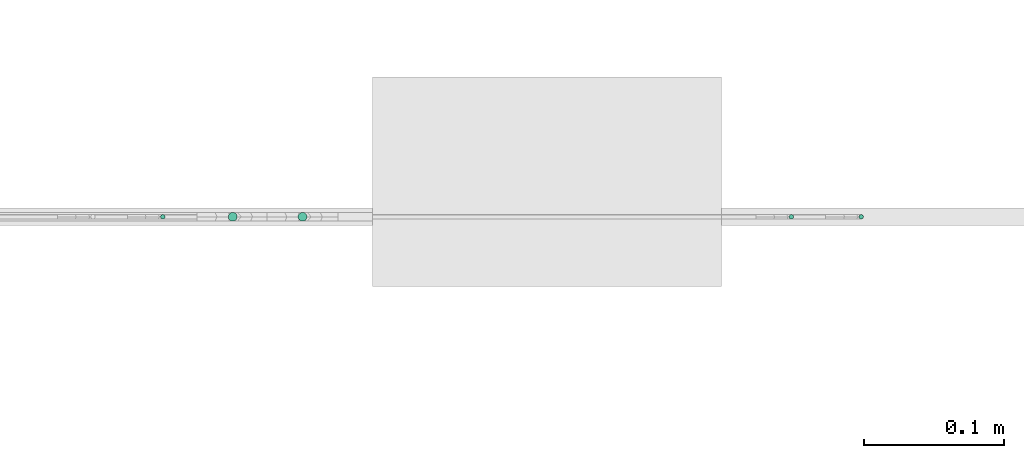
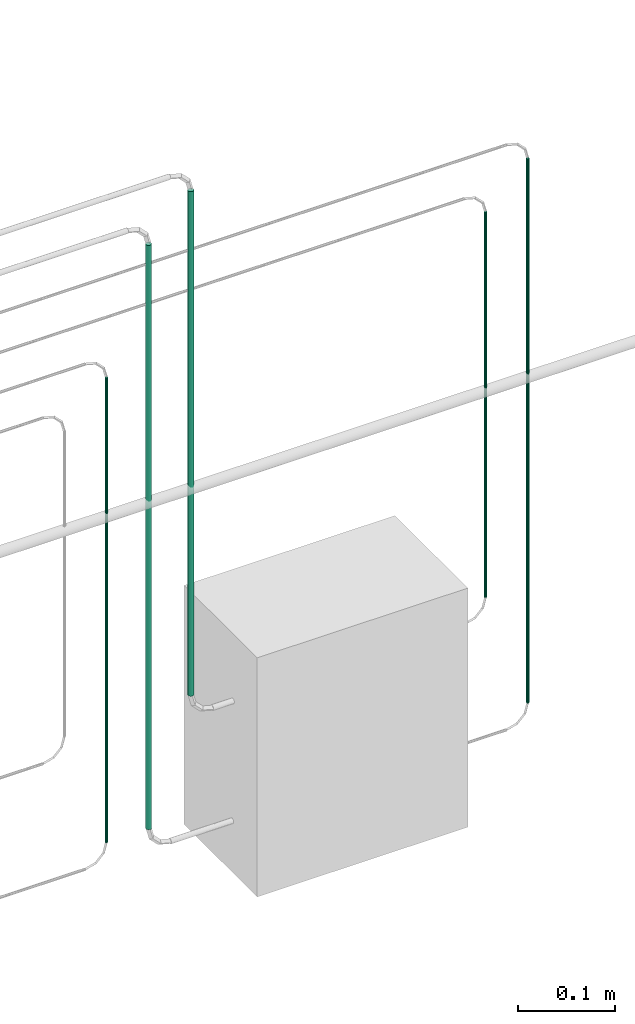
# One storey, part 24 of 45: 5 flow segments.
"""IFC2X3 building model written with IfcOpenShell, lengths in millimetres."""

from ifc_helpers import new_model, entity, si_unit, converted_unit, derived_unit, direction, frame, origin, origin_2d_with_axis, place, context, subcontext, project, spatial, circle, extrude, type_object, element, save


model = new_model("IFC2X3")

# Units and contexts
model_context = context("Model", 3, precision=0.01, world=origin(), true_north=direction((6.12303176911189e-17, 1.0)))
body_context = subcontext(model_context, "Body", "Model", "MODEL_VIEW")
ifc_project = project(units=[si_unit("LENGTHUNIT", "METRE", prefix="MILLI"), si_unit("AREAUNIT", "SQUARE_METRE"), si_unit("VOLUMEUNIT", "CUBIC_METRE"), converted_unit("PLANEANGLEUNIT", "DEGREE", entity("IfcRatioMeasure", 0.0174532925199433), si_unit("PLANEANGLEUNIT", "RADIAN"), dimensions=[0, 0, 0, 0, 0, 0, 0]), si_unit("MASSUNIT", "GRAM", prefix="KILO"), derived_unit("MASSDENSITYUNIT", [(si_unit("MASSUNIT", "GRAM", prefix="KILO"), 1), (si_unit("LENGTHUNIT", "METRE"), -3)]), derived_unit("MOMENTOFINERTIAUNIT", [(si_unit("LENGTHUNIT", "METRE"), 4)]), si_unit("TIMEUNIT", "SECOND"), si_unit("FREQUENCYUNIT", "HERTZ"), si_unit("THERMODYNAMICTEMPERATUREUNIT", "DEGREE_CELSIUS"), derived_unit("THERMALTRANSMITTANCEUNIT", [(si_unit("MASSUNIT", "GRAM", prefix="KILO"), 1), (si_unit("THERMODYNAMICTEMPERATUREUNIT", "KELVIN"), -1), (si_unit("TIMEUNIT", "SECOND"), -3)]), derived_unit("VOLUMETRICFLOWRATEUNIT", [(si_unit("LENGTHUNIT", "METRE"), 3), (si_unit("TIMEUNIT", "SECOND"), -1)]), derived_unit("MASSFLOWRATEUNIT", [(si_unit("MASSUNIT", "GRAM", prefix="KILO"), 1), (si_unit("TIMEUNIT", "SECOND"), -1)]), derived_unit("ROTATIONALFREQUENCYUNIT", [(si_unit("TIMEUNIT", "SECOND"), -1)]), si_unit("ELECTRICCURRENTUNIT", "AMPERE"), si_unit("ELECTRICVOLTAGEUNIT", "VOLT"), si_unit("POWERUNIT", "WATT"), si_unit("FORCEUNIT", "NEWTON", prefix="KILO"), si_unit("ILLUMINANCEUNIT", "LUX"), si_unit("LUMINOUSFLUXUNIT", "LUMEN"), si_unit("LUMINOUSINTENSITYUNIT", "CANDELA"), derived_unit("USERDEFINED", [(si_unit("MASSUNIT", "GRAM", prefix="KILO"), -1), (si_unit("LENGTHUNIT", "METRE"), -2), (si_unit("TIMEUNIT", "SECOND"), 3), (si_unit("LUMINOUSFLUXUNIT", "LUMEN"), 1)]), derived_unit("LINEARVELOCITYUNIT", [(si_unit("LENGTHUNIT", "METRE"), 1), (si_unit("TIMEUNIT", "SECOND"), -1)]), si_unit("PRESSUREUNIT", "PASCAL"), derived_unit("USERDEFINED", [(si_unit("LENGTHUNIT", "METRE"), -2), (si_unit("MASSUNIT", "GRAM", prefix="KILO"), 1), (si_unit("TIMEUNIT", "SECOND"), -2)]), derived_unit("LINEARFORCEUNIT", [(si_unit("MASSUNIT", "GRAM", prefix="KILO"), 1), (si_unit("LENGTHUNIT", "METRE"), 1), (si_unit("TIMEUNIT", "SECOND"), -2), (si_unit("LENGTHUNIT", "METRE"), -1)]), derived_unit("PLANARFORCEUNIT", [(si_unit("MASSUNIT", "GRAM", prefix="KILO"), 1), (si_unit("LENGTHUNIT", "METRE"), 1), (si_unit("TIMEUNIT", "SECOND"), -2), (si_unit("LENGTHUNIT", "METRE"), -2)])], contexts=[model_context])

# Site, building, storey
site_placement = place(None, frame((-24836.06, 8968.75, 0.0)))
site = spatial("IfcSite", under=ifc_project, at=site_placement, CompositionType="ELEMENT")
building_placement = place(site_placement, origin())
building = spatial("IfcBuilding", under=site, at=building_placement, CompositionType="ELEMENT")
storey_placement = place(building_placement, frame((0.0, 0.0, -4200.0)))
storey = spatial("IfcBuildingStorey", under=building, at=storey_placement, CompositionType="ELEMENT", Elevation=-4200.0)

# Flow segments
pipe_segment_type = type_object("IfcPipeSegmentType", PredefinedType="NOTDEFINED")
flow_segment_1_placement = place(storey_placement, frame((81817.01, -7593.52, 1591.46)))
element("IfcFlowSegment", 1, at=flow_segment_1_placement, inside=storey, type_object=pipe_segment_type, context=body_context, shape_type="SweptSolid", body=[
    extrude(circle(Radius=3.175, at=origin_2d_with_axis()), frame((4.77, 4.77, 0.0)), (0.0, 0.0, 1.0), 733.138220786856),
])
flow_segment_2_placement = place(storey_placement, frame((81867.01, -7593.52, 1741.46)))
element("IfcFlowSegment", 2, at=flow_segment_2_placement, inside=storey, type_object=pipe_segment_type, context=body_context, shape_type="SweptSolid", body=[
    extrude(circle(Radius=3.175, at=origin_2d_with_axis()), frame((4.77, 4.77, 0.0)), (0.0, 0.0, 1.0), 633.138220786858),
])
flow_segment_3_placement = place(storey_placement, frame((82218.6, -7591.94, 1741.46)))
element("IfcFlowSegment", 3, at=flow_segment_3_placement, inside=storey, type_object=pipe_segment_type, context=body_context, shape_type="SweptSolid", body=[
    extrude(circle(Radius=1.59, at=origin_2d_with_axis()), frame((3.19, 3.19, 0.0), z_axis=(0.0, 0.0, 1.0), x_axis=(-1.0, 0.0, 0.0)), (0.0, 0.0, 1.0), 483.138220786849),
])
flow_segment_4_placement = place(storey_placement, frame((81768.54, -7591.94, 1591.46)))
element("IfcFlowSegment", 4, at=flow_segment_4_placement, inside=storey, type_object=pipe_segment_type, context=body_context, shape_type="SweptSolid", body=[
    extrude(circle(Radius=1.59, at=origin_2d_with_axis()), frame((3.19, 3.19, 0.0), z_axis=(0.0, 0.0, 1.0), x_axis=(-1.0, 0.0, 0.0)), (0.0, 0.0, 1.0), 583.138220786858),
])
flow_segment_5_placement = place(storey_placement, frame((82268.6, -7591.94, 1591.46)))
element("IfcFlowSegment", 5, at=flow_segment_5_placement, inside=storey, type_object=pipe_segment_type, context=body_context, shape_type="SweptSolid", body=[
    extrude(circle(Radius=1.59, at=origin_2d_with_axis()), frame((3.19, 3.19, 0.0)), (0.0, 0.0, 1.0), 683.138220786845),
])

save(model, "model.ifc")
